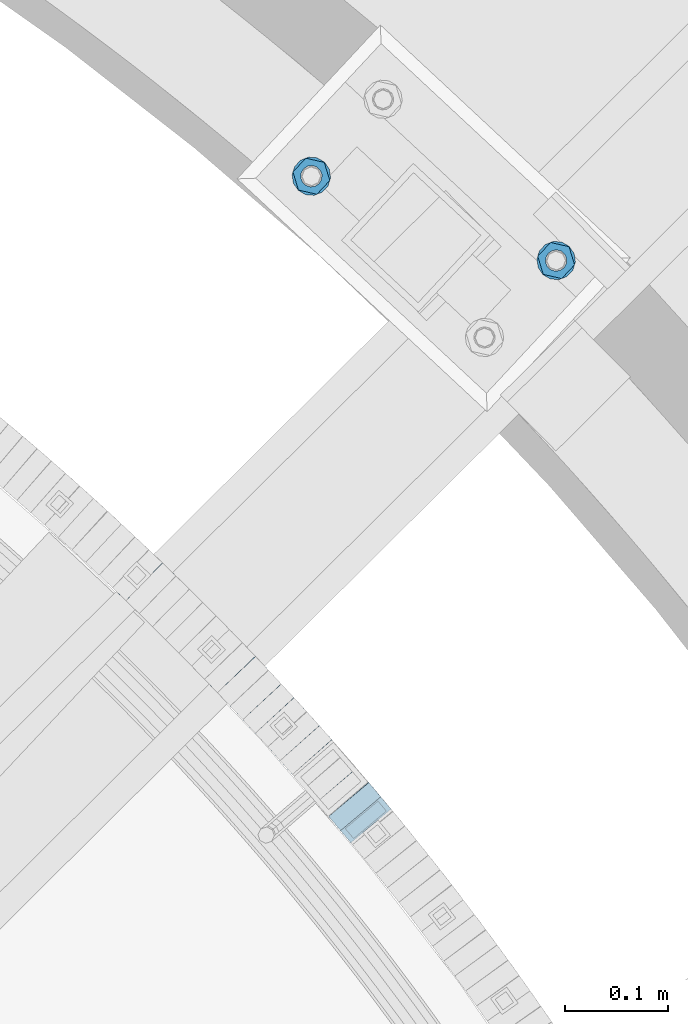
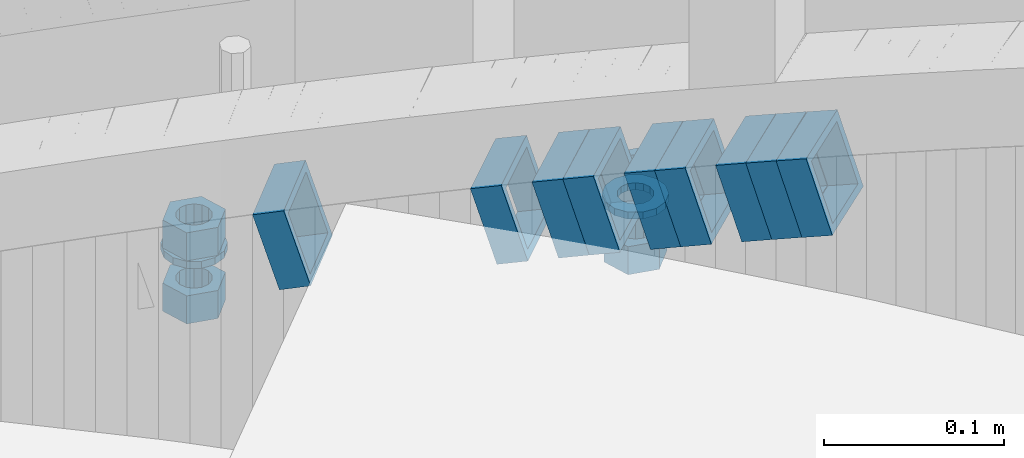
# One storey, part 812 of 975: 15 beams.
"""IFC2X3 building model written with IfcOpenShell, lengths in millimetres."""

from ifc_helpers import new_model, si_unit, frame, origin_with_axes, place, context, subcontext, project, spatial, faceted_brep, material, type_object, element, save


model = new_model("IFC2X3")

# Units and contexts
model_context = context("Model", 3, precision=1e-05, world=origin_with_axes())
body_context = subcontext(model_context, "Body", "Model", "MODEL_VIEW")
ifc_project = project(units=[si_unit("LENGTHUNIT", "METRE", prefix="MILLI"), si_unit("AREAUNIT", "SQUARE_METRE"), si_unit("VOLUMEUNIT", "CUBIC_METRE"), si_unit("MASSUNIT", "GRAM", prefix="KILO"), si_unit("TIMEUNIT", "SECOND"), si_unit("PLANEANGLEUNIT", "RADIAN"), si_unit("SOLIDANGLEUNIT", "STERADIAN"), si_unit("THERMODYNAMICTEMPERATUREUNIT", "DEGREE_CELSIUS"), si_unit("LUMINOUSINTENSITYUNIT", "LUMEN")], contexts=[model_context])

# Site, building, storey
site_placement = place(None, origin_with_axes())
site = spatial("IfcSite", under=ifc_project, at=site_placement, CompositionType="ELEMENT")
building_placement = place(site_placement, origin_with_axes())
building = spatial("IfcBuilding", under=site, at=building_placement, Name="Undefined", CompositionType="ELEMENT")
storey_placement = place(building_placement, origin_with_axes())
storey = spatial("IfcBuildingStorey", under=building, at=storey_placement, Name="Undefined", CompositionType="ELEMENT", Elevation=0.0)

# Beams
ifc_material_1 = material()
beam_type_1 = type_object("IfcBeamType", Name="HSS2X2X.188_TUBES", PredefinedType="NOTDEFINED")
beam_1_placement = place(storey_placement, frame((36940.3883940815, 5240.68108650307, 1839.79909807573), z_axis=(-0.765925091094034, -0.642929821078939, 0.0), x_axis=(-0.612578014121225, 0.729766851144523, -0.30362562406013)))
element("IfcBeam", 1, at=beam_1_placement, inside=storey, type_object=beam_type_1, material=ifc_material_1, Name="WALL", ObjectType="HSS2X2X.188_TUBES", context=body_context, shape_type="Brep", body=[
    faceted_brep([(0.0, 20.6374999999753, -20.6375000000298), (0.0, -20.6375000000153, -20.6375000000153), (18.767258723612, -20.6375000000025, -20.6374999999862), (18.7672587236229, 20.6374999999953, -20.637499999968), (0.0, -20.6374999999825, 20.6375000000335), (18.767258723612, -20.6375000000135, 20.6375000000153), (0.0, 20.6375000000116, 20.6375000000189), (18.7672587236266, 20.6374999999844, 20.6375000000371), (0.0, 25.3999999999724, -25.4000000000342), (0.0, 25.400000000016, 25.4000000000196), (18.7672587236302, 25.3999999999814, 25.4000000000342), (18.7672587236229, 25.399999999996, -25.3999999999687), (0.0, -25.399999999976, 25.4000000000378), (18.7672587236157, -25.4000000000142, 25.400000000016), (0.0, -25.400000000016, -25.4000000000196), (18.767258723612, -25.4000000000015, -25.3999999999905)], [[[0, 1, 2, 3]], [[1, 4, 5, 2]], [[4, 6, 7, 5]], [[6, 0, 3, 7]], [[8, 9, 10, 11]], [[9, 12, 13, 10]], [[12, 14, 15, 13]], [[14, 8, 11, 15]], [[13, 15, 11, 10], [5, 7, 3, 2]], [[14, 12, 9, 8], [6, 4, 1, 0]]]),
])
beam_2_placement = place(storey_placement, frame((36928.808465944, 5254.56967674524, 1834.10056426539), z_axis=(-0.760833952017173, -0.648946606014648, 0.0), x_axis=(-0.618273295243763, 0.724872139285741, -0.30380670511977)))
element("IfcBeam", 2, at=beam_2_placement, inside=storey, type_object=beam_type_1, material=ifc_material_1, Name="WALL", ObjectType="HSS2X2X.188_TUBES", context=body_context, shape_type="Brep", body=[
    faceted_brep([(0.0, 20.6374999999753, -20.6375000000298), (0.0, -20.6375000000153, -20.6375000000153), (18.7555325170906, -20.6374999999916, -20.6374999999971), (18.7555325171452, 20.637499999988, -20.6374999999571), (0.0, -20.6374999999825, 20.6375000000335), (18.7555325170615, -20.6374999999844, 20.6374999999716), (0.0, 20.6375000000116, 20.6375000000189), (18.7555325171015, 20.6374999999953, 20.637500000008), (0.0, 25.3999999999724, -25.4000000000342), (0.0, 25.400000000016, 25.4000000000196), (18.7555325171015, 25.399999999996, 25.4000000000051), (18.7555325171488, 25.3999999999851, -25.3999999999505), (0.0, -25.399999999976, 25.4000000000378), (18.755532517047, -25.3999999999814, 25.3999999999578), (0.0, -25.400000000016, -25.4000000000196), (18.7555325170979, -25.3999999999924, -25.3999999999978)], [[[0, 1, 2, 3]], [[1, 4, 5, 2]], [[4, 6, 7, 5]], [[6, 0, 3, 7]], [[8, 9, 10, 11]], [[9, 12, 13, 10]], [[12, 14, 15, 13]], [[14, 8, 11, 15]], [[13, 15, 11, 10], [5, 7, 3, 2]], [[14, 12, 9, 8], [6, 4, 1, 0]]]),
])
beam_3_placement = place(storey_placement, frame((36917.1890841458, 5268.23566218761, 1828.4101116252), z_axis=(-0.758462874763348, -0.651716247768703, -6.7902874434367e-12), x_axis=(-0.620667058927777, 0.722328042916032, -0.304982950964539)))
element("IfcBeam", 3, at=beam_3_placement, inside=storey, type_object=beam_type_1, material=ifc_material_1, Name="WALL", ObjectType="HSS2X2X.188_TUBES", context=body_context, shape_type="Brep", body=[
    faceted_brep([(0.0, 20.6374999999753, -20.6375000000298), (0.0, -20.6375000000153, -20.6375000000153), (18.6895692834223, -20.637499999988, -20.6374999999862), (18.6895692834369, 20.6374999999953, -20.6374999999534), (0.0, -20.6374999999825, 20.6375000000335), (18.6895692833914, -20.637499999988, 20.6374999999789), (0.0, 20.6375000000116, 20.6375000000189), (18.6895692834078, 20.6374999999953, 20.637500000008), (0.0, 25.3999999999724, -25.4000000000342), (0.0, 25.400000000016, 25.4000000000196), (18.6895692834059, 25.3999999999924, 25.4000000000087), (18.6895692834423, 25.3999999999942, -25.3999999999432), (0.0, -25.399999999976, 25.4000000000378), (18.6895692833878, -25.3999999999869, 25.3999999999687), (0.0, -25.400000000016, -25.4000000000196), (18.6895692834241, -25.3999999999869, -25.3999999999833)], [[[0, 1, 2, 3]], [[1, 4, 5, 2]], [[4, 6, 7, 5]], [[6, 0, 3, 7]], [[8, 9, 10, 11]], [[9, 12, 13, 10]], [[12, 14, 15, 13]], [[14, 8, 11, 15]], [[13, 15, 11, 10], [5, 7, 3, 2]], [[14, 12, 9, 8], [6, 4, 1, 0]]]),
])
beam_4_placement = place(storey_placement, frame((36893.5796277023, 5295.56716967766, 1816.89482477381), z_axis=(-0.747717099182229, -0.664017424161831, 0.0), x_axis=(-0.632781815205622, 0.712544229231421, -0.303097172098453)))
element("IfcBeam", 4, at=beam_4_placement, inside=storey, type_object=beam_type_1, material=ifc_material_1, Name="WALL", ObjectType="HSS2X2X.188_TUBES", context=body_context, shape_type="Brep", body=[
    faceted_brep([(0.0, 20.6374999999753, -20.6375000000298), (0.0, -20.6375000000153, -20.6375000000153), (18.8066477608099, -20.6374999999862, -20.6375000000116), (18.8066477608172, 20.6375000000062, -20.6374999999971), (0.0, -20.6374999999825, 20.6375000000335), (18.8066477608463, -20.6375000000062, 20.6375000000407), (0.0, 20.6375000000116, 20.6375000000189), (18.8066477608536, 20.6374999999844, 20.637500000048), (0.0, 25.3999999999724, -25.4000000000342), (0.0, 25.400000000016, 25.4000000000196), (18.8066477608591, 25.3999999999814, 25.400000000056), (18.8066477608154, 25.4000000000051, -25.4000000000015), (0.0, -25.399999999976, 25.4000000000378), (18.8066477608518, -25.4000000000087, 25.4000000000451), (0.0, -25.400000000016, -25.4000000000196), (18.8066477608081, -25.3999999999851, -25.4000000000196)], [[[0, 1, 2, 3]], [[1, 4, 5, 2]], [[4, 6, 7, 5]], [[6, 0, 3, 7]], [[8, 9, 10, 11]], [[9, 12, 13, 10]], [[12, 14, 15, 13]], [[14, 8, 11, 15]], [[13, 15, 11, 10], [5, 7, 3, 2]], [[14, 12, 9, 8], [6, 4, 1, 0]]]),
])
beam_5_placement = place(storey_placement, frame((36881.657613455, 5309.03499590919, 1811.20413999274), z_axis=(-0.745241313969715, -0.666794858972902, 0.0), x_axis=(-0.635184058038659, 0.709911595043062, -0.304247826018456)))
element("IfcBeam", 5, at=beam_5_placement, inside=storey, type_object=beam_type_1, material=ifc_material_1, Name="WALL", ObjectType="HSS2X2X.188_TUBES", context=body_context, shape_type="Brep", body=[
    faceted_brep([(0.0, 20.6374999999753, -20.6375000000298), (0.0, -20.6375000000153, -20.6375000000153), (18.7347271129966, -20.6375000000116, -20.6375000000262), (18.7347271130257, 20.6374999999989, -20.6374999999935), (0.0, -20.6374999999825, 20.6375000000335), (18.7347271129947, -20.6375000000116, 20.6374999999607), (0.0, 20.6375000000116, 20.6375000000189), (18.7347271130147, 20.6375000000007, 20.6374999999898), (0.0, 25.3999999999724, -25.4000000000342), (0.0, 25.400000000016, 25.4000000000196), (18.7347271130166, 25.4000000000015, 25.3999999999905), (18.7347271130257, 25.3999999999996, -25.3999999999869), (0.0, -25.399999999976, 25.4000000000378), (18.7347271129875, -25.4000000000106, 25.3999999999505), (0.0, -25.400000000016, -25.4000000000196), (18.7347271130002, -25.4000000000124, -25.4000000000233)], [[[0, 1, 2, 3]], [[1, 4, 5, 2]], [[4, 6, 7, 5]], [[6, 0, 3, 7]], [[8, 9, 10, 11]], [[9, 12, 13, 10]], [[12, 14, 15, 13]], [[14, 8, 11, 15]], [[13, 15, 11, 10], [5, 7, 3, 2]], [[14, 12, 9, 8], [6, 4, 1, 0]]]),
])
beam_6_placement = place(storey_placement, frame((36857.4811754009, 5335.91107465515, 1799.70583007291), z_axis=(-0.734588421928499, -0.678512969933956, 0.0), x_axis=(-0.646301499982323, 0.699714846980964, -0.304456078991709)))
element("IfcBeam", 6, at=beam_6_placement, inside=storey, type_object=beam_type_1, material=ifc_material_1, Name="WALL", ObjectType="HSS2X2X.188_TUBES", context=body_context, shape_type="Brep", body=[
    faceted_brep([(0.0, 20.6374999999753, -20.6375000000298), (0.0, -20.6375000000153, -20.6375000000153), (18.724849799155, -20.6375000000171, -20.6374999999425), (18.7248497991204, 20.6374999999989, -20.6375000000007), (0.0, -20.6374999999825, 20.6375000000335), (18.7248497991168, -20.6374999999953, 20.6375000000007), (0.0, 20.6375000000116, 20.6375000000189), (18.724849799084, 20.6375000000226, 20.6374999999498), (0.0, 25.3999999999724, -25.4000000000342), (0.0, 25.400000000016, 25.4000000000196), (18.7248497990731, 25.4000000000269, 25.399999999936), (18.7248497991204, 25.3999999999978, -25.3999999999978), (0.0, -25.399999999976, 25.4000000000378), (18.7248497991186, -25.3999999999942, 25.4000000000051), (0.0, -25.400000000016, -25.4000000000196), (18.7248497991604, -25.4000000000233, -25.3999999999323)], [[[0, 1, 2, 3]], [[1, 4, 5, 2]], [[4, 6, 7, 5]], [[6, 0, 3, 7]], [[8, 9, 10, 11]], [[9, 12, 13, 10]], [[12, 14, 15, 13]], [[14, 8, 11, 15]], [[13, 15, 11, 10], [5, 7, 3, 2]], [[14, 12, 9, 8], [6, 4, 1, 0]]]),
])
beam_7_placement = place(storey_placement, frame((36845.3153886886, 5349.12859146415, 1793.99732251225), z_axis=(-0.731797897769698, -0.681521706785522, 0.0), x_axis=(-0.649395672152563, 0.697301910163839, -0.303406175071277)))
element("IfcBeam", 7, at=beam_7_placement, inside=storey, type_object=beam_type_1, material=ifc_material_1, Name="WALL", ObjectType="HSS2X2X.188_TUBES", context=body_context, shape_type="Brep", body=[
    faceted_brep([(0.0, 20.6374999999753, -20.6375000000298), (0.0, -20.6375000000153, -20.6375000000153), (18.7853666454903, -20.6375000000535, -20.6375000000326), (18.785366645363, 20.6374999999862, -20.6375000000044), (0.0, -20.6374999999825, 20.6375000000335), (18.785366645352, -20.6375000000007, 20.6374999999989), (0.0, 20.6375000000116, 20.6375000000189), (18.7853666453102, 20.6375000000025, 20.6374999999753), (0.0, 25.3999999999724, -25.4000000000342), (0.0, 25.400000000016, 25.4000000000196), (18.7853666452065, 25.4000000000451, 25.4000000000351), (18.7853666453739, 25.3999999999833, -25.400000000006), (0.0, -25.399999999976, 25.4000000000378), (18.7853666497213, -25.399999993424, 25.3999999995158), (0.0, -25.400000000016, -25.4000000000196), (18.7853666455194, -25.4000000000633, -25.4000000000406)], [[[0, 1, 2, 3]], [[1, 4, 5, 2]], [[4, 6, 7, 5]], [[6, 0, 3, 7]], [[8, 9, 10, 11]], [[9, 12, 13, 10]], [[12, 14, 15, 13]], [[14, 8, 11, 15]], [[13, 15, 11, 10], [5, 7, 3, 2]], [[14, 12, 9, 8], [6, 4, 1, 0]]]),
])
for number, where, z_axis, x_axis, name in (
    (8, (36820.6301638689, 5375.60153237233, 1782.49829667917), (-0.720940448280083, -0.692997020219938, -1.13200258056168e-11), (-0.660303476135118, 0.686928616140521, -0.303526598062095), "WALL"),
    (9, (36731.735832764, 5465.42672742144, 1742.29829667879), (-0.692997020219874, -0.720940448280144, 1.1348902262398e-11), (-0.686928616140586, 0.660303476135052, -0.303526598062089), "WALL"),
):
    element("IfcBeam", number, at=place(storey_placement, frame(where, z_axis=z_axis, x_axis=x_axis)), inside=storey, type_object=beam_type_1, material=ifc_material_1, Name=name, ObjectType="HSS2X2X.188_TUBES", context=body_context, shape_type="Brep", body=[
        faceted_brep([(0.0, 20.6374999999753, -20.6375000000298), (0.0, -20.6375000000153, -20.6375000000153), (18.7771137292038, -20.637500000008, -20.6374999999862), (18.777113729182, 20.6375000000062, -20.6375000000189), (0.0, -20.6374999999825, 20.6375000000335), (18.7771137291729, -20.6374999999916, 20.6374999999753), (0.0, 20.6375000000116, 20.6375000000189), (18.7771137291529, 20.6375000000207, 20.6374999999389), (0.0, 25.3999999999724, -25.4000000000342), (0.0, 25.400000000016, 25.4000000000196), (18.7771137291475, 25.4000000000251, 25.3999999999287), (18.7771137291857, 25.4000000000051, -25.4000000000196), (0.0, -25.399999999976, 25.4000000000378), (18.7771137291711, -25.3999999999905, 25.3999999999724), (0.0, -25.400000000016, -25.4000000000196), (18.7771137292129, -25.4000000000124, -25.3999999999724)], [[[0, 1, 2, 3]], [[1, 4, 5, 2]], [[4, 6, 7, 5]], [[6, 0, 3, 7]], [[8, 9, 10, 11]], [[9, 12, 13, 10]], [[12, 14, 15, 13]], [[14, 8, 11, 15]], [[13, 15, 11, 10], [5, 7, 3, 2]], [[14, 12, 9, 8], [6, 4, 1, 0]]]),
    ])
ifc_material_2 = material(Name="STEEL/A36")
beam_type_2 = type_object("IfcBeamType", Name="3/4_WASHER", PredefinedType="NOTDEFINED")
beam_8_placement = place(storey_placement, frame((37124.3022421513, 5781.13190493337, 1433.5125), z_axis=(-0.73176109614993, 0.68156122113971, 0.0), x_axis=(0.0, 0.0, -1.0)))
element("IfcBeam", 10, at=beam_8_placement, inside=storey, type_object=beam_type_2, material=ifc_material_2, Name="WASHER", ObjectType="3/4_WASHER", context=body_context, shape_type="Brep", body=[
    faceted_brep([(0.0, -18.6499996185303, 0.0), (0.0, -16.8030690426876, -8.09193156902904), (4.76250000000073, -16.8030690426876, -8.09193156902904), (4.76250000000073, -18.6499996185303, 0.0), (0.0, -11.6280845668225, -14.5811568497838), (4.76250000000073, -11.6280845668225, -14.5811568497838), (0.0, -4.15001533340001, -18.1824051902857), (4.76250000000073, -4.15001533340001, -18.1824051902857), (0.0, 4.15001533340001, -18.1824051902857), (4.76250000000073, 4.15001533340001, -18.1824051902857), (0.0, 11.6280845668234, -14.5811568497838), (4.76250000000073, 11.6280845668234, -14.5811568497838), (0.0, 16.8030690426876, -8.09193156902904), (4.76250000000073, 16.8030690426876, -8.09193156902904), (0.0, 18.6499996185303, 0.0), (4.76250000000073, 18.6499996185303, 0.0), (0.0, 16.8030690426876, 8.09193156902904), (4.76250000000073, 16.8030690426876, 8.09193156902904), (0.0, 11.6280845668225, 14.5811568497838), (4.76250000000073, 11.6280845668225, 14.5811568497838), (0.0, 4.15001533340001, 18.1824051902857), (4.76250000000073, 4.15001533340001, 18.1824051902857), (0.0, -4.15001533340001, 18.1824051902857), (4.76250000000073, -4.15001533340001, 18.1824051902857), (0.0, -11.6280845668234, 14.5811568497838), (4.76250000000073, -11.6280845668234, 14.5811568497838), (0.0, -16.8030690426876, 8.09193156902904), (4.76250000000073, -16.8030690426876, 8.09193156902904), (0.0, 0.0, 10.3199996948242), (0.0, 4.47768005528269, 9.29799844179911), (4.76250000000073, 4.47768005528269, 9.29799844179911), (4.76250000000073, 0.0, 10.3199996948242), (0.0, 8.06850066047446, 6.43441456490817), (4.76250000000073, 8.06850066047446, 6.43441456490817), (0.0, 10.0612557561917, 2.29641597052117), (4.76250000000073, 10.0612557561917, 2.29641597052117), (0.0, 10.0612557561917, -2.29641597052117), (4.76250000000073, 10.0612557561917, -2.29641597052117), (0.0, 8.06850066047446, -6.43441456490814), (4.76250000000073, 8.06850066047446, -6.43441456490814), (0.0, 4.47768005528269, -9.29799844179908), (4.76250000000073, 4.47768005528269, -9.29799844179908), (0.0, 0.0, -10.3199996948242), (4.76250000000073, 0.0, -10.3199996948242), (0.0, -4.47768005528269, -9.29799844179911), (4.76250000000073, -4.47768005528269, -9.29799844179911), (0.0, -8.06850066047446, -6.43441456490817), (4.76250000000073, -8.06850066047446, -6.43441456490817), (0.0, -10.0612557561917, -2.29641597052117), (4.76250000000073, -10.0612557561917, -2.29641597052117), (0.0, -10.0612557561917, 2.29641597052117), (4.76250000000073, -10.0612557561917, 2.29641597052117), (0.0, -8.06850066047446, 6.43441456490814), (4.76250000000073, -8.06850066047446, 6.43441456490814), (0.0, -4.47768005528269, 9.29799844179908), (4.76250000000073, -4.47768005528269, 9.29799844179908)], [[[0, 1, 2, 3]], [[1, 4, 5, 2]], [[4, 6, 7, 5]], [[6, 8, 9, 7]], [[8, 10, 11, 9]], [[10, 12, 13, 11]], [[12, 14, 15, 13]], [[14, 16, 17, 15]], [[16, 18, 19, 17]], [[18, 20, 21, 19]], [[20, 22, 23, 21]], [[22, 24, 25, 23]], [[24, 26, 27, 25]], [[26, 0, 3, 27]], [[28, 29, 30, 31]], [[29, 32, 33, 30]], [[32, 34, 35, 33]], [[34, 36, 37, 35]], [[36, 38, 39, 37]], [[38, 40, 41, 39]], [[40, 42, 43, 41]], [[42, 44, 45, 43]], [[44, 46, 47, 45]], [[46, 48, 49, 47]], [[48, 50, 51, 49]], [[50, 52, 53, 51]], [[52, 54, 55, 53]], [[54, 28, 31, 55]], [[5, 7, 9, 11, 13, 15, 17, 19, 21, 23, 25, 27, 3, 2], [33, 35, 37, 39, 41, 43, 45, 47, 49, 51, 53, 55, 31, 30]], [[26, 24, 22, 20, 18, 16, 14, 12, 10, 8, 6, 4, 1, 0], [54, 52, 50, 48, 46, 44, 42, 40, 38, 36, 34, 32, 29, 28]]]),
])
beam_9_placement = place(storey_placement, frame((36887.7750399706, 5862.58986855397, 1433.5125), z_axis=(0.73176109614993, -0.68156122113971, 0.0), x_axis=(0.0, 0.0, -1.0)))
element("IfcBeam", 11, at=beam_9_placement, inside=storey, type_object=beam_type_2, material=ifc_material_2, Name="WASHER", ObjectType="3/4_WASHER", context=body_context, shape_type="Brep", body=[
    faceted_brep([(0.0, -18.6499996185303, 0.0), (0.0, -16.8030690426876, -8.09193156902904), (4.76250000000073, -16.8030690426876, -8.09193156902904), (4.76250000000073, -18.6499996185303, 0.0), (0.0, -11.6280845668225, -14.5811568497838), (4.76250000000073, -11.6280845668225, -14.5811568497838), (0.0, -4.15001533340001, -18.1824051902857), (4.76250000000073, -4.15001533340001, -18.1824051902857), (0.0, 4.15001533340001, -18.1824051902857), (4.76250000000073, 4.15001533340001, -18.1824051902857), (0.0, 11.6280845668234, -14.5811568497838), (4.76250000000073, 11.6280845668234, -14.5811568497838), (0.0, 16.8030690426876, -8.09193156902904), (4.76250000000073, 16.8030690426876, -8.09193156902904), (0.0, 18.6499996185303, 0.0), (4.76250000000073, 18.6499996185303, 0.0), (0.0, 16.8030690426876, 8.09193156902904), (4.76250000000073, 16.8030690426876, 8.09193156902904), (0.0, 11.6280845668225, 14.5811568497838), (4.76250000000073, 11.6280845668225, 14.5811568497838), (0.0, 4.15001533340001, 18.1824051902857), (4.76250000000073, 4.15001533340001, 18.1824051902857), (0.0, -4.15001533340001, 18.1824051902857), (4.76250000000073, -4.15001533340001, 18.1824051902857), (0.0, -11.6280845668234, 14.5811568497838), (4.76250000000073, -11.6280845668234, 14.5811568497838), (0.0, -16.8030690426876, 8.09193156902904), (4.76250000000073, -16.8030690426876, 8.09193156902904), (0.0, 0.0, 10.3199996948242), (0.0, 4.47768005528269, 9.29799844179911), (4.76250000000073, 4.47768005528269, 9.29799844179911), (4.76250000000073, 0.0, 10.3199996948242), (0.0, 8.06850066047446, 6.43441456490817), (4.76250000000073, 8.06850066047446, 6.43441456490817), (0.0, 10.0612557561917, 2.29641597052117), (4.76250000000073, 10.0612557561917, 2.29641597052117), (0.0, 10.0612557561917, -2.29641597052117), (4.76250000000073, 10.0612557561917, -2.29641597052117), (0.0, 8.06850066047446, -6.43441456490814), (4.76250000000073, 8.06850066047446, -6.43441456490814), (0.0, 4.47768005528269, -9.29799844179908), (4.76250000000073, 4.47768005528269, -9.29799844179908), (0.0, 0.0, -10.3199996948242), (4.76250000000073, 0.0, -10.3199996948242), (0.0, -4.47768005528269, -9.29799844179911), (4.76250000000073, -4.47768005528269, -9.29799844179911), (0.0, -8.06850066047446, -6.43441456490817), (4.76250000000073, -8.06850066047446, -6.43441456490817), (0.0, -10.0612557561917, -2.29641597052117), (4.76250000000073, -10.0612557561917, -2.29641597052117), (0.0, -10.0612557561917, 2.29641597052117), (4.76250000000073, -10.0612557561917, 2.29641597052117), (0.0, -8.06850066047446, 6.43441456490814), (4.76250000000073, -8.06850066047446, 6.43441456490814), (0.0, -4.47768005528269, 9.29799844179908), (4.76250000000073, -4.47768005528269, 9.29799844179908)], [[[0, 1, 2, 3]], [[1, 4, 5, 2]], [[4, 6, 7, 5]], [[6, 8, 9, 7]], [[8, 10, 11, 9]], [[10, 12, 13, 11]], [[12, 14, 15, 13]], [[14, 16, 17, 15]], [[16, 18, 19, 17]], [[18, 20, 21, 19]], [[20, 22, 23, 21]], [[22, 24, 25, 23]], [[24, 26, 27, 25]], [[26, 0, 3, 27]], [[28, 29, 30, 31]], [[29, 32, 33, 30]], [[32, 34, 35, 33]], [[34, 36, 37, 35]], [[36, 38, 39, 37]], [[38, 40, 41, 39]], [[40, 42, 43, 41]], [[42, 44, 45, 43]], [[44, 46, 47, 45]], [[46, 48, 49, 47]], [[48, 50, 51, 49]], [[50, 52, 53, 51]], [[52, 54, 55, 53]], [[54, 28, 31, 55]], [[5, 7, 9, 11, 13, 15, 17, 19, 21, 23, 25, 27, 3, 2], [33, 35, 37, 39, 41, 43, 45, 47, 49, 51, 53, 55, 31, 30]], [[26, 24, 22, 20, 18, 16, 14, 12, 10, 8, 6, 4, 1, 0], [54, 52, 50, 48, 46, 44, 42, 40, 38, 36, 34, 32, 29, 28]]]),
])
beam_type_3 = type_object("IfcBeamType", Name="3/4_HEAVY_HEX_NUT", PredefinedType="NOTDEFINED")
beam_10_placement = place(storey_placement, frame((37124.3022421513, 5781.13190493337, 1452.5625), z_axis=(-0.73176109614993, 0.68156122113971, 0.0), x_axis=(0.0, 0.0, -1.0)))
element("IfcBeam", 12, at=beam_10_placement, inside=storey, type_object=beam_type_3, material=ifc_material_2, Name="NUT", ObjectType="3/4_HEAVY_HEX_NUT", context=body_context, shape_type="Brep", body=[
    faceted_brep([(0.0, -18.2600002288818, 0.0), (0.0, -9.13000011444092, -15.8100004196167), (19.0499999999993, -9.13000011444092, -15.8100004196167), (19.0499999999993, -18.2600002288818, 0.0), (0.0, 9.13000011444092, -15.8100004196167), (19.0499999999993, 9.13000011444092, -15.8100004196167), (0.0, 18.2600002288818, 0.0), (19.0499999999993, 18.2600002288818, 0.0), (0.0, 9.13000011444092, 15.8100004196167), (19.0499999999993, 9.13000011444092, 15.8100004196167), (0.0, -9.13000011444092, 15.8100004196167), (19.0499999999993, -9.13000011444092, 15.8100004196167), (0.0, 0.0, 10.3199996948242), (0.0, 4.47768005528269, 9.29799844179911), (19.0499999999993, 4.47768005528269, 9.29799844179911), (19.0499999999993, 0.0, 10.3199996948242), (0.0, 8.06850066047446, 6.43441456490817), (19.0499999999993, 8.06850066047446, 6.43441456490817), (0.0, 10.0612557561917, 2.29641597052117), (19.0499999999993, 10.0612557561917, 2.29641597052117), (0.0, 10.0612557561917, -2.29641597052117), (19.0499999999993, 10.0612557561917, -2.29641597052117), (0.0, 8.06850066047446, -6.43441456490814), (19.0499999999993, 8.06850066047446, -6.43441456490814), (0.0, 4.47768005528269, -9.29799844179908), (19.0499999999993, 4.47768005528269, -9.29799844179908), (0.0, 0.0, -10.3199996948242), (19.0499999999993, 0.0, -10.3199996948242), (0.0, -4.47768005528269, -9.29799844179911), (19.0499999999993, -4.47768005528269, -9.29799844179911), (0.0, -8.06850066047446, -6.43441456490817), (19.0499999999993, -8.06850066047446, -6.43441456490817), (0.0, -10.0612557561917, -2.29641597052117), (19.0499999999993, -10.0612557561917, -2.29641597052117), (0.0, -10.0612557561917, 2.29641597052117), (19.0499999999993, -10.0612557561917, 2.29641597052117), (0.0, -8.06850066047446, 6.43441456490814), (19.0499999999993, -8.06850066047446, 6.43441456490814), (0.0, -4.47768005528269, 9.29799844179908), (19.0499999999993, -4.47768005528269, 9.29799844179908)], [[[0, 1, 2, 3]], [[1, 4, 5, 2]], [[4, 6, 7, 5]], [[6, 8, 9, 7]], [[8, 10, 11, 9]], [[10, 0, 3, 11]], [[12, 13, 14, 15]], [[13, 16, 17, 14]], [[16, 18, 19, 17]], [[18, 20, 21, 19]], [[20, 22, 23, 21]], [[22, 24, 25, 23]], [[24, 26, 27, 25]], [[26, 28, 29, 27]], [[28, 30, 31, 29]], [[30, 32, 33, 31]], [[32, 34, 35, 33]], [[34, 36, 37, 35]], [[36, 38, 39, 37]], [[38, 12, 15, 39]], [[5, 7, 9, 11, 3, 2], [17, 19, 21, 23, 25, 27, 29, 31, 33, 35, 37, 39, 15, 14]], [[10, 8, 6, 4, 1, 0], [38, 36, 34, 32, 30, 28, 26, 24, 22, 20, 18, 16, 13, 12]]]),
])
beam_11_placement = place(storey_placement, frame((37124.3022421513, 5781.13190493337, 1409.7), z_axis=(-0.73176109614993, 0.68156122113971, 0.0), x_axis=(0.0, 0.0, -1.0)))
element("IfcBeam", 13, at=beam_11_placement, inside=storey, type_object=beam_type_3, material=ifc_material_2, Name="NUT", ObjectType="3/4_HEAVY_HEX_NUT", context=body_context, shape_type="Brep", body=[
    faceted_brep([(0.0, -18.2600002288818, 0.0), (0.0, -9.13000011444092, -15.8100004196167), (19.0499999999993, -9.13000011444092, -15.8100004196167), (19.0499999999993, -18.2600002288818, 0.0), (0.0, 9.13000011444092, -15.8100004196167), (19.0499999999993, 9.13000011444092, -15.8100004196167), (0.0, 18.2600002288818, 0.0), (19.0499999999993, 18.2600002288818, 0.0), (0.0, 9.13000011444092, 15.8100004196167), (19.0499999999993, 9.13000011444092, 15.8100004196167), (0.0, -9.13000011444092, 15.8100004196167), (19.0499999999993, -9.13000011444092, 15.8100004196167), (0.0, 0.0, 10.3199996948242), (0.0, 4.47768005528269, 9.29799844179911), (19.0499999999993, 4.47768005528269, 9.29799844179911), (19.0499999999993, 0.0, 10.3199996948242), (0.0, 8.06850066047446, 6.43441456490817), (19.0499999999993, 8.06850066047446, 6.43441456490817), (0.0, 10.0612557561917, 2.29641597052117), (19.0499999999993, 10.0612557561917, 2.29641597052117), (0.0, 10.0612557561917, -2.29641597052117), (19.0499999999993, 10.0612557561917, -2.29641597052117), (0.0, 8.06850066047446, -6.43441456490814), (19.0499999999993, 8.06850066047446, -6.43441456490814), (0.0, 4.47768005528269, -9.29799844179908), (19.0499999999993, 4.47768005528269, -9.29799844179908), (0.0, 0.0, -10.3199996948242), (19.0499999999993, 0.0, -10.3199996948242), (0.0, -4.47768005528269, -9.29799844179911), (19.0499999999993, -4.47768005528269, -9.29799844179911), (0.0, -8.06850066047446, -6.43441456490817), (19.0499999999993, -8.06850066047446, -6.43441456490817), (0.0, -10.0612557561917, -2.29641597052117), (19.0499999999993, -10.0612557561917, -2.29641597052117), (0.0, -10.0612557561917, 2.29641597052117), (19.0499999999993, -10.0612557561917, 2.29641597052117), (0.0, -8.06850066047446, 6.43441456490814), (19.0499999999993, -8.06850066047446, 6.43441456490814), (0.0, -4.47768005528269, 9.29799844179908), (19.0499999999993, -4.47768005528269, 9.29799844179908)], [[[0, 1, 2, 3]], [[1, 4, 5, 2]], [[4, 6, 7, 5]], [[6, 8, 9, 7]], [[8, 10, 11, 9]], [[10, 0, 3, 11]], [[12, 13, 14, 15]], [[13, 16, 17, 14]], [[16, 18, 19, 17]], [[18, 20, 21, 19]], [[20, 22, 23, 21]], [[22, 24, 25, 23]], [[24, 26, 27, 25]], [[26, 28, 29, 27]], [[28, 30, 31, 29]], [[30, 32, 33, 31]], [[32, 34, 35, 33]], [[34, 36, 37, 35]], [[36, 38, 39, 37]], [[38, 12, 15, 39]], [[5, 7, 9, 11, 3, 2], [17, 19, 21, 23, 25, 27, 29, 31, 33, 35, 37, 39, 15, 14]], [[10, 8, 6, 4, 1, 0], [38, 36, 34, 32, 30, 28, 26, 24, 22, 20, 18, 16, 13, 12]]]),
])
beam_12_placement = place(storey_placement, frame((36887.7750399706, 5862.58986855397, 1452.5625), z_axis=(0.73176109614993, -0.68156122113971, 0.0), x_axis=(0.0, 0.0, -1.0)))
element("IfcBeam", 14, at=beam_12_placement, inside=storey, type_object=beam_type_3, material=ifc_material_2, Name="NUT", ObjectType="3/4_HEAVY_HEX_NUT", context=body_context, shape_type="Brep", body=[
    faceted_brep([(0.0, -18.2600002288818, 0.0), (0.0, -9.13000011444092, -15.8100004196167), (19.0499999999993, -9.13000011444092, -15.8100004196167), (19.0499999999993, -18.2600002288818, 0.0), (0.0, 9.13000011444092, -15.8100004196167), (19.0499999999993, 9.13000011444092, -15.8100004196167), (0.0, 18.2600002288818, 0.0), (19.0499999999993, 18.2600002288818, 0.0), (0.0, 9.13000011444092, 15.8100004196167), (19.0499999999993, 9.13000011444092, 15.8100004196167), (0.0, -9.13000011444092, 15.8100004196167), (19.0499999999993, -9.13000011444092, 15.8100004196167), (0.0, 0.0, 10.3199996948242), (0.0, 4.47768005528269, 9.29799844179911), (19.0499999999993, 4.47768005528269, 9.29799844179911), (19.0499999999993, 0.0, 10.3199996948242), (0.0, 8.06850066047446, 6.43441456490817), (19.0499999999993, 8.06850066047446, 6.43441456490817), (0.0, 10.0612557561917, 2.29641597052117), (19.0499999999993, 10.0612557561917, 2.29641597052117), (0.0, 10.0612557561917, -2.29641597052117), (19.0499999999993, 10.0612557561917, -2.29641597052117), (0.0, 8.06850066047446, -6.43441456490814), (19.0499999999993, 8.06850066047446, -6.43441456490814), (0.0, 4.47768005528269, -9.29799844179908), (19.0499999999993, 4.47768005528269, -9.29799844179908), (0.0, 0.0, -10.3199996948242), (19.0499999999993, 0.0, -10.3199996948242), (0.0, -4.47768005528269, -9.29799844179911), (19.0499999999993, -4.47768005528269, -9.29799844179911), (0.0, -8.06850066047446, -6.43441456490817), (19.0499999999993, -8.06850066047446, -6.43441456490817), (0.0, -10.0612557561917, -2.29641597052117), (19.0499999999993, -10.0612557561917, -2.29641597052117), (0.0, -10.0612557561917, 2.29641597052117), (19.0499999999993, -10.0612557561917, 2.29641597052117), (0.0, -8.06850066047446, 6.43441456490814), (19.0499999999993, -8.06850066047446, 6.43441456490814), (0.0, -4.47768005528269, 9.29799844179908), (19.0499999999993, -4.47768005528269, 9.29799844179908)], [[[0, 1, 2, 3]], [[1, 4, 5, 2]], [[4, 6, 7, 5]], [[6, 8, 9, 7]], [[8, 10, 11, 9]], [[10, 0, 3, 11]], [[12, 13, 14, 15]], [[13, 16, 17, 14]], [[16, 18, 19, 17]], [[18, 20, 21, 19]], [[20, 22, 23, 21]], [[22, 24, 25, 23]], [[24, 26, 27, 25]], [[26, 28, 29, 27]], [[28, 30, 31, 29]], [[30, 32, 33, 31]], [[32, 34, 35, 33]], [[34, 36, 37, 35]], [[36, 38, 39, 37]], [[38, 12, 15, 39]], [[5, 7, 9, 11, 3, 2], [17, 19, 21, 23, 25, 27, 29, 31, 33, 35, 37, 39, 15, 14]], [[10, 8, 6, 4, 1, 0], [38, 36, 34, 32, 30, 28, 26, 24, 22, 20, 18, 16, 13, 12]]]),
])
beam_13_placement = place(storey_placement, frame((36887.7750399706, 5862.58986855397, 1409.7), z_axis=(0.73176109614993, -0.68156122113971, 0.0), x_axis=(0.0, 0.0, -1.0)))
element("IfcBeam", 15, at=beam_13_placement, inside=storey, type_object=beam_type_3, material=ifc_material_2, Name="NUT", ObjectType="3/4_HEAVY_HEX_NUT", context=body_context, shape_type="Brep", body=[
    faceted_brep([(0.0, -18.2600002288818, 0.0), (0.0, -9.13000011444092, -15.8100004196167), (19.0499999999993, -9.13000011444092, -15.8100004196167), (19.0499999999993, -18.2600002288818, 0.0), (0.0, 9.13000011444092, -15.8100004196167), (19.0499999999993, 9.13000011444092, -15.8100004196167), (0.0, 18.2600002288818, 0.0), (19.0499999999993, 18.2600002288818, 0.0), (0.0, 9.13000011444092, 15.8100004196167), (19.0499999999993, 9.13000011444092, 15.8100004196167), (0.0, -9.13000011444092, 15.8100004196167), (19.0499999999993, -9.13000011444092, 15.8100004196167), (0.0, 0.0, 10.3199996948242), (0.0, 4.47768005528269, 9.29799844179911), (19.0499999999993, 4.47768005528269, 9.29799844179911), (19.0499999999993, 0.0, 10.3199996948242), (0.0, 8.06850066047446, 6.43441456490817), (19.0499999999993, 8.06850066047446, 6.43441456490817), (0.0, 10.0612557561917, 2.29641597052117), (19.0499999999993, 10.0612557561917, 2.29641597052117), (0.0, 10.0612557561917, -2.29641597052117), (19.0499999999993, 10.0612557561917, -2.29641597052117), (0.0, 8.06850066047446, -6.43441456490814), (19.0499999999993, 8.06850066047446, -6.43441456490814), (0.0, 4.47768005528269, -9.29799844179908), (19.0499999999993, 4.47768005528269, -9.29799844179908), (0.0, 0.0, -10.3199996948242), (19.0499999999993, 0.0, -10.3199996948242), (0.0, -4.47768005528269, -9.29799844179911), (19.0499999999993, -4.47768005528269, -9.29799844179911), (0.0, -8.06850066047446, -6.43441456490817), (19.0499999999993, -8.06850066047446, -6.43441456490817), (0.0, -10.0612557561917, -2.29641597052117), (19.0499999999993, -10.0612557561917, -2.29641597052117), (0.0, -10.0612557561917, 2.29641597052117), (19.0499999999993, -10.0612557561917, 2.29641597052117), (0.0, -8.06850066047446, 6.43441456490814), (19.0499999999993, -8.06850066047446, 6.43441456490814), (0.0, -4.47768005528269, 9.29799844179908), (19.0499999999993, -4.47768005528269, 9.29799844179908)], [[[0, 1, 2, 3]], [[1, 4, 5, 2]], [[4, 6, 7, 5]], [[6, 8, 9, 7]], [[8, 10, 11, 9]], [[10, 0, 3, 11]], [[12, 13, 14, 15]], [[13, 16, 17, 14]], [[16, 18, 19, 17]], [[18, 20, 21, 19]], [[20, 22, 23, 21]], [[22, 24, 25, 23]], [[24, 26, 27, 25]], [[26, 28, 29, 27]], [[28, 30, 31, 29]], [[30, 32, 33, 31]], [[32, 34, 35, 33]], [[34, 36, 37, 35]], [[36, 38, 39, 37]], [[38, 12, 15, 39]], [[5, 7, 9, 11, 3, 2], [17, 19, 21, 23, 25, 27, 29, 31, 33, 35, 37, 39, 15, 14]], [[10, 8, 6, 4, 1, 0], [38, 36, 34, 32, 30, 28, 26, 24, 22, 20, 18, 16, 13, 12]]]),
])

save(model, "model.ifc")
